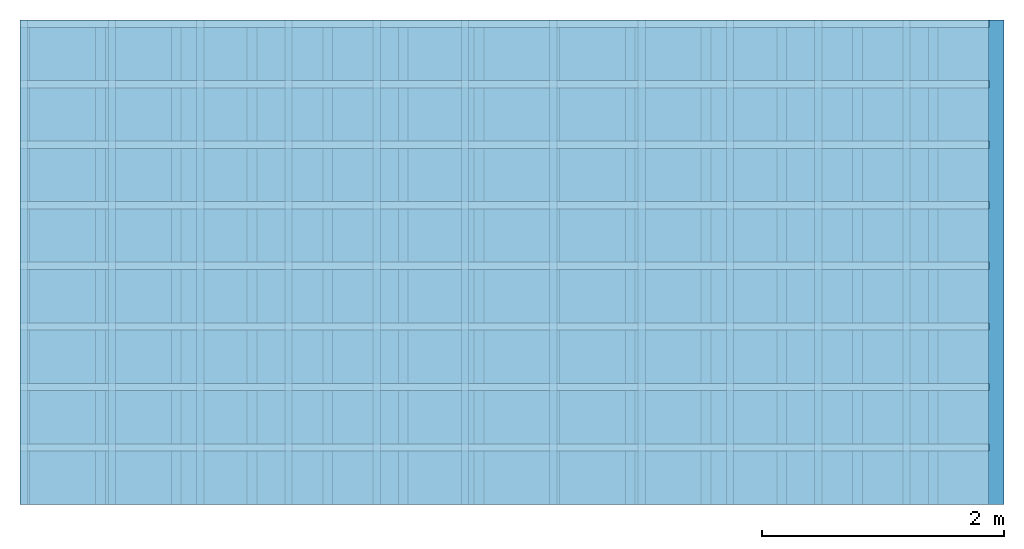
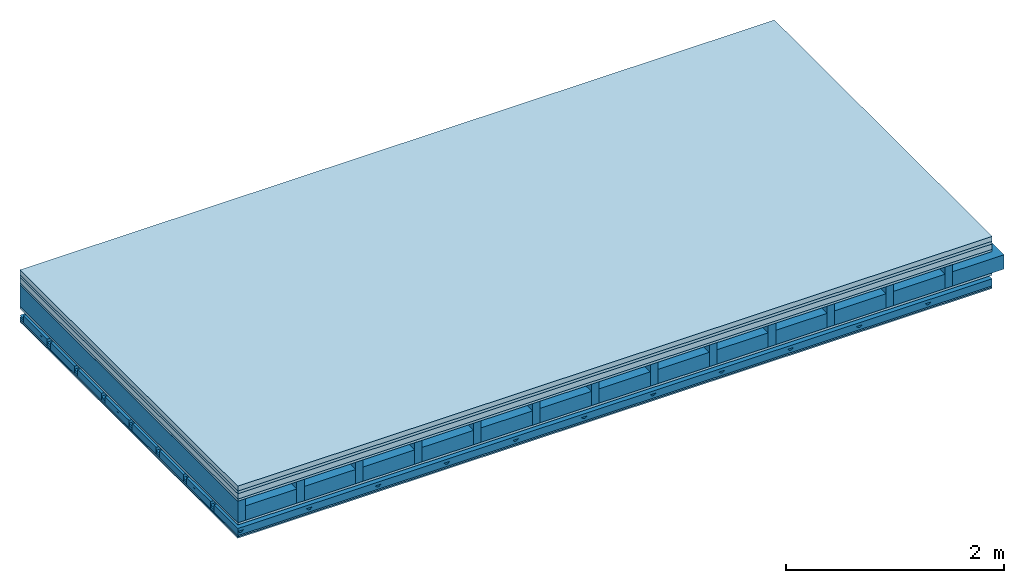
# One storey: 7 plates, 5 members, 1 element without a shape of its own.
"""IFC4 building model written with IfcOpenShell, lengths in metres."""

from ifc_helpers import new_model, si_unit, derived_unit, direction, frame, frame_2d, origin, origin_with_axes, place, context, project, spatial, polyline, rectangle, outline, extrude, material, layer, layer_set, type_object, element, aggregate, save


model = new_model("IFC4")

# Units and contexts
plan_context = context("Plan", 3, precision=1e-05, world=origin(), true_north=direction((0.0, 1.0)))
model_context = context("Model", 3, precision=1e-05, world=origin(), true_north=direction((0.0, 1.0)))
ifc_project = project(units=[si_unit("LENGTHUNIT", "METRE"), derived_unit("SOUNDPRESSUREUNIT", [(si_unit("PRESSUREUNIT", "PASCAL", prefix="MICRO"), 0)]), si_unit("ENERGYUNIT", "JOULE", prefix="MEGA"), si_unit("MASSUNIT", "GRAM", prefix="KILO"), derived_unit("THERMALTRANSMITTANCEUNIT", [(si_unit("POWERUNIT", "WATT"), 1), (si_unit("AREAUNIT", "SQUARE_METRE"), -1), (si_unit("THERMODYNAMICTEMPERATUREUNIT", "KELVIN"), -1)]), derived_unit("AREADENSITYUNIT", [(si_unit("MASSUNIT", "GRAM", prefix="KILO"), 1), (si_unit("AREAUNIT", "SQUARE_METRE"), -1)]), derived_unit("USERDEFINED", [(si_unit("ENERGYUNIT", "JOULE", prefix="MEGA"), 1), (si_unit("AREAUNIT", "SQUARE_METRE"), -1)])], contexts=[plan_context, model_context])

# Site, building, storey
site = spatial("IfcSite", under=ifc_project)
building_placement = place(None, origin())
building = spatial("IfcBuilding", under=site, at=building_placement)
storey_placement = place(building_placement, origin())
storey = spatial("IfcBuildingStorey", under=building, at=storey_placement)

# Slab, members, plates
ifc_material_1 = material(Category="04.005")
ifc_layer_1 = layer(ifc_material_1, 0.055, Name="On-material")
ifc_material_2 = material()
ifc_layer_2 = layer(ifc_material_2, 0.03, Name="Impact sound insulation")
ifc_material_3 = material(Name="Cement panels, glued on sub-floor", Category="02.007")
ifc_layer_3 = layer(ifc_material_3, 0.06, Name="on Supporting structure")
ifc_material_4 = material(Category="07.001")
ifc_layer_4 = layer(ifc_material_4, 0.025, Name="Sub-floor")
ifc_material_5 = material(Name="Rigid, of the art")
ifc_layer_5 = layer(ifc_material_5, 0.0, Name="Bond")
ifc_layer_6 = layer(None, 0.24, Name="Supporting structure")
ifc_layer_7 = layer(ifc_material_5, 0.0, Name="Bond")
ifc_layer_8 = layer(ifc_material_4, 0.025, Name="Lower layer 1")
ifc_layer_9 = layer(None, 0.093, Name="Coupling")
ifc_layer_10 = layer(None, 0.027, Name="Battens / profiles")
ifc_material_6 = material(Category="03.007")
ifc_layer_11 = layer(ifc_material_6, 0.015, Name="Ceiling covering 1st layer")
ifc_layer_12 = layer(ifc_material_6, 0.015, Name="Ceiling covering layer 2")
ifc_material_7 = material(Name="Glued joints")
ifc_layer_13 = layer(ifc_material_7, 0.0, Name="Surface / treatment")
ifc_layer_set = layer_set([ifc_layer_1, ifc_layer_2, ifc_layer_3, ifc_layer_4, ifc_layer_5, ifc_layer_6, ifc_layer_7, ifc_layer_8, ifc_layer_9, ifc_layer_10, ifc_layer_11, ifc_layer_12, ifc_layer_13])
slab_type = type_object("IfcSlabType", Name="A0520", PredefinedType="NOTDEFINED", material=ifc_layer_set)
slab_placement = place(None, frame((0.0, 0.0, 0.0), z_axis=(0.0, 0.0, -1.0), x_axis=(1.0, 0.0, 0.0)))
slab = element("IfcSlab", 1, at=slab_placement, inside=storey, type_object=slab_type, material=ifc_layer_set, Name="Slab #1")
ifc_material_8 = material()
member_1_placement = place(slab_placement, origin())
member_1 = element("IfcMember", 2, at=member_1_placement, material=ifc_material_8, Name="Supporting structure", context=plan_context, shape_type="SweptSolid", body=[
    extrude(rectangle(XDim=0.08, YDim=0.24, at=frame_2d((0.04, 0.12), x_axis=(1.0, 0.0))), frame((0.0, 4.0, 0.17), z_axis=(0.0, -1.0, 0.0), x_axis=(1.0, 0.0, 0.0)), (0.0, 0.0, 1.0), 4.0),
    extrude(rectangle(XDim=0.08, YDim=0.24, at=frame_2d((0.04, 0.12), x_axis=(1.0, 0.0))), frame((0.625, 4.0, 0.17), z_axis=(0.0, -1.0, 0.0), x_axis=(1.0, 0.0, 0.0)), (0.0, 0.0, 1.0), 4.0),
    extrude(rectangle(XDim=0.08, YDim=0.24, at=frame_2d((0.04, 0.12), x_axis=(1.0, 0.0))), frame((1.25, 4.0, 0.17), z_axis=(0.0, -1.0, 0.0), x_axis=(1.0, 0.0, 0.0)), (0.0, 0.0, 1.0), 4.0),
    extrude(rectangle(XDim=0.08, YDim=0.24, at=frame_2d((0.04, 0.12), x_axis=(1.0, 0.0))), frame((1.875, 4.0, 0.17), z_axis=(0.0, -1.0, 0.0), x_axis=(1.0, 0.0, 0.0)), (0.0, 0.0, 1.0), 4.0),
    extrude(rectangle(XDim=0.08, YDim=0.24, at=frame_2d((0.04, 0.12), x_axis=(1.0, 0.0))), frame((2.5, 4.0, 0.17), z_axis=(0.0, -1.0, 0.0), x_axis=(1.0, 0.0, 0.0)), (0.0, 0.0, 1.0), 4.0),
    extrude(rectangle(XDim=0.08, YDim=0.24, at=frame_2d((0.04, 0.12), x_axis=(1.0, 0.0))), frame((3.125, 4.0, 0.17), z_axis=(0.0, -1.0, 0.0), x_axis=(1.0, 0.0, 0.0)), (0.0, 0.0, 1.0), 4.0),
    extrude(rectangle(XDim=0.08, YDim=0.24, at=frame_2d((0.04, 0.12), x_axis=(1.0, 0.0))), frame((3.75, 4.0, 0.17), z_axis=(0.0, -1.0, 0.0), x_axis=(1.0, 0.0, 0.0)), (0.0, 0.0, 1.0), 4.0),
    extrude(rectangle(XDim=0.08, YDim=0.24, at=frame_2d((0.04, 0.12), x_axis=(1.0, 0.0))), frame((4.375, 4.0, 0.17), z_axis=(0.0, -1.0, 0.0), x_axis=(1.0, 0.0, 0.0)), (0.0, 0.0, 1.0), 4.0),
    extrude(rectangle(XDim=0.08, YDim=0.24, at=frame_2d((0.04, 0.12), x_axis=(1.0, 0.0))), frame((5.0, 4.0, 0.17), z_axis=(0.0, -1.0, 0.0), x_axis=(1.0, 0.0, 0.0)), (0.0, 0.0, 1.0), 4.0),
    extrude(rectangle(XDim=0.08, YDim=0.24, at=frame_2d((0.04, 0.12), x_axis=(1.0, 0.0))), frame((5.625, 4.0, 0.17), z_axis=(0.0, -1.0, 0.0), x_axis=(1.0, 0.0, 0.0)), (0.0, 0.0, 1.0), 4.0),
    extrude(rectangle(XDim=0.08, YDim=0.24, at=frame_2d((0.04, 0.12), x_axis=(1.0, 0.0))), frame((6.25, 4.0, 0.17), z_axis=(0.0, -1.0, 0.0), x_axis=(1.0, 0.0, 0.0)), (0.0, 0.0, 1.0), 4.0),
    extrude(rectangle(XDim=0.08, YDim=0.24, at=frame_2d((0.04, 0.12), x_axis=(1.0, 0.0))), frame((6.875, 4.0, 0.17), z_axis=(0.0, -1.0, 0.0), x_axis=(1.0, 0.0, 0.0)), (0.0, 0.0, 1.0), 4.0),
    extrude(rectangle(XDim=0.08, YDim=0.24, at=frame_2d((0.04, 0.12), x_axis=(1.0, 0.0))), frame((7.5, 4.0, 0.17), z_axis=(0.0, -1.0, 0.0), x_axis=(1.0, 0.0, 0.0)), (0.0, 0.0, 1.0), 4.0),
])
ifc_material_9 = material()
member_2_placement = place(slab_placement, origin())
member_2 = element("IfcMember", 3, at=member_2_placement, material=ifc_material_9, Name="Cavity", context=plan_context, shape_type="SweptSolid", body=[
    extrude(rectangle(XDim=0.545, YDim=0.16, at=frame_2d((0.2725, 0.08), x_axis=(1.0, 0.0))), frame((0.08, 4.0, 0.25), z_axis=(0.0, -1.0, 0.0), x_axis=(1.0, 0.0, 0.0)), (0.0, 0.0, 1.0), 4.0),
    extrude(rectangle(XDim=0.545, YDim=0.16, at=frame_2d((0.2725, 0.08), x_axis=(1.0, 0.0))), frame((0.705, 4.0, 0.25), z_axis=(0.0, -1.0, 0.0), x_axis=(1.0, 0.0, 0.0)), (0.0, 0.0, 1.0), 4.0),
    extrude(rectangle(XDim=0.545, YDim=0.16, at=frame_2d((0.2725, 0.08), x_axis=(1.0, 0.0))), frame((1.33, 4.0, 0.25), z_axis=(0.0, -1.0, 0.0), x_axis=(1.0, 0.0, 0.0)), (0.0, 0.0, 1.0), 4.0),
    extrude(rectangle(XDim=0.545, YDim=0.16, at=frame_2d((0.2725, 0.08), x_axis=(1.0, 0.0))), frame((1.955, 4.0, 0.25), z_axis=(0.0, -1.0, 0.0), x_axis=(1.0, 0.0, 0.0)), (0.0, 0.0, 1.0), 4.0),
    extrude(rectangle(XDim=0.545, YDim=0.16, at=frame_2d((0.2725, 0.08), x_axis=(1.0, 0.0))), frame((2.58, 4.0, 0.25), z_axis=(0.0, -1.0, 0.0), x_axis=(1.0, 0.0, 0.0)), (0.0, 0.0, 1.0), 4.0),
    extrude(rectangle(XDim=0.545, YDim=0.16, at=frame_2d((0.2725, 0.08), x_axis=(1.0, 0.0))), frame((3.205, 4.0, 0.25), z_axis=(0.0, -1.0, 0.0), x_axis=(1.0, 0.0, 0.0)), (0.0, 0.0, 1.0), 4.0),
    extrude(rectangle(XDim=0.545, YDim=0.16, at=frame_2d((0.2725, 0.08), x_axis=(1.0, 0.0))), frame((3.83, 4.0, 0.25), z_axis=(0.0, -1.0, 0.0), x_axis=(1.0, 0.0, 0.0)), (0.0, 0.0, 1.0), 4.0),
    extrude(rectangle(XDim=0.545, YDim=0.16, at=frame_2d((0.2725, 0.08), x_axis=(1.0, 0.0))), frame((4.455, 4.0, 0.25), z_axis=(0.0, -1.0, 0.0), x_axis=(1.0, 0.0, 0.0)), (0.0, 0.0, 1.0), 4.0),
    extrude(rectangle(XDim=0.545, YDim=0.16, at=frame_2d((0.2725, 0.08), x_axis=(1.0, 0.0))), frame((5.08, 4.0, 0.25), z_axis=(0.0, -1.0, 0.0), x_axis=(1.0, 0.0, 0.0)), (0.0, 0.0, 1.0), 4.0),
    extrude(rectangle(XDim=0.545, YDim=0.16, at=frame_2d((0.2725, 0.08), x_axis=(1.0, 0.0))), frame((5.705, 4.0, 0.25), z_axis=(0.0, -1.0, 0.0), x_axis=(1.0, 0.0, 0.0)), (0.0, 0.0, 1.0), 4.0),
    extrude(rectangle(XDim=0.545, YDim=0.16, at=frame_2d((0.2725, 0.08), x_axis=(1.0, 0.0))), frame((6.33, 4.0, 0.25), z_axis=(0.0, -1.0, 0.0), x_axis=(1.0, 0.0, 0.0)), (0.0, 0.0, 1.0), 4.0),
    extrude(rectangle(XDim=0.545, YDim=0.16, at=frame_2d((0.2725, 0.08), x_axis=(1.0, 0.0))), frame((6.955, 4.0, 0.25), z_axis=(0.0, -1.0, 0.0), x_axis=(1.0, 0.0, 0.0)), (0.0, 0.0, 1.0), 4.0),
    extrude(rectangle(XDim=0.545, YDim=0.16, at=frame_2d((0.2725, 0.08), x_axis=(1.0, 0.0))), frame((7.58, 4.0, 0.25), z_axis=(0.0, -1.0, 0.0), x_axis=(1.0, 0.0, 0.0)), (0.0, 0.0, 1.0), 4.0),
])
ifc_material_10 = material()
member_3_placement = place(slab_placement, origin())
member_3 = element("IfcMember", 4, at=member_3_placement, material=ifc_material_10, Name="Coupling", context=plan_context, shape_type="SweptSolid", body=[
    extrude(outline(polyline([(0.0, 0.0), (0.06, 0.0), (0.04, 0.02), (0.02, 0.02), (0.0, 0.0)])), frame((0.0, 4.0, 0.508), z_axis=(0.0, -1.0, 0.0), x_axis=(1.0, 0.0, 0.0)), (0.0, 0.0, 1.0), 4.0),
    extrude(outline(polyline([(0.0, 0.0), (0.06, 0.0), (0.04, 0.02), (0.02, 0.02), (0.0, 0.0)])), frame((0.729, 4.0, 0.508), z_axis=(0.0, -1.0, 0.0), x_axis=(1.0, 0.0, 0.0)), (0.0, 0.0, 1.0), 4.0),
    extrude(outline(polyline([(0.0, 0.0), (0.06, 0.0), (0.04, 0.02), (0.02, 0.02), (0.0, 0.0)])), frame((1.458, 4.0, 0.508), z_axis=(0.0, -1.0, 0.0), x_axis=(1.0, 0.0, 0.0)), (0.0, 0.0, 1.0), 4.0),
    extrude(outline(polyline([(0.0, 0.0), (0.06, 0.0), (0.04, 0.02), (0.02, 0.02), (0.0, 0.0)])), frame((2.187, 4.0, 0.508), z_axis=(0.0, -1.0, 0.0), x_axis=(1.0, 0.0, 0.0)), (0.0, 0.0, 1.0), 4.0),
    extrude(outline(polyline([(0.0, 0.0), (0.06, 0.0), (0.04, 0.02), (0.02, 0.02), (0.0, 0.0)])), frame((2.916, 4.0, 0.508), z_axis=(0.0, -1.0, 0.0), x_axis=(1.0, 0.0, 0.0)), (0.0, 0.0, 1.0), 4.0),
    extrude(outline(polyline([(0.0, 0.0), (0.06, 0.0), (0.04, 0.02), (0.02, 0.02), (0.0, 0.0)])), frame((3.645, 4.0, 0.508), z_axis=(0.0, -1.0, 0.0), x_axis=(1.0, 0.0, 0.0)), (0.0, 0.0, 1.0), 4.0),
    extrude(outline(polyline([(0.0, 0.0), (0.06, 0.0), (0.04, 0.02), (0.02, 0.02), (0.0, 0.0)])), frame((4.374, 4.0, 0.508), z_axis=(0.0, -1.0, 0.0), x_axis=(1.0, 0.0, 0.0)), (0.0, 0.0, 1.0), 4.0),
    extrude(outline(polyline([(0.0, 0.0), (0.06, 0.0), (0.04, 0.02), (0.02, 0.02), (0.0, 0.0)])), frame((5.103, 4.0, 0.508), z_axis=(0.0, -1.0, 0.0), x_axis=(1.0, 0.0, 0.0)), (0.0, 0.0, 1.0), 4.0),
    extrude(outline(polyline([(0.0, 0.0), (0.06, 0.0), (0.04, 0.02), (0.02, 0.02), (0.0, 0.0)])), frame((5.832, 4.0, 0.508), z_axis=(0.0, -1.0, 0.0), x_axis=(1.0, 0.0, 0.0)), (0.0, 0.0, 1.0), 4.0),
    extrude(outline(polyline([(0.0, 0.0), (0.06, 0.0), (0.04, 0.02), (0.02, 0.02), (0.0, 0.0)])), frame((6.561, 4.0, 0.508), z_axis=(0.0, -1.0, 0.0), x_axis=(1.0, 0.0, 0.0)), (0.0, 0.0, 1.0), 4.0),
    extrude(outline(polyline([(0.0, 0.0), (0.06, 0.0), (0.04, 0.02), (0.02, 0.02), (0.0, 0.0)])), frame((7.29, 4.0, 0.508), z_axis=(0.0, -1.0, 0.0), x_axis=(1.0, 0.0, 0.0)), (0.0, 0.0, 1.0), 4.0),
])
ifc_material_11 = material()
member_4_placement = place(slab_placement, origin())
member_4 = element("IfcMember", 5, at=member_4_placement, material=ifc_material_11, Name="Battens / profiles", context=plan_context, shape_type="SweptSolid", body=[
    extrude(rectangle(XDim=0.06, YDim=0.027, at=frame_2d((0.03, 0.0135), x_axis=(1.0, 0.0))), frame((0.0, 0.0, 0.528), z_axis=(1.0, 0.0, 0.0), x_axis=(0.0, 1.0, 0.0)), (0.0, 0.0, 1.0), 8.0),
    extrude(rectangle(XDim=0.06, YDim=0.027, at=frame_2d((0.03, 0.0135), x_axis=(1.0, 0.0))), frame((0.0, 0.5, 0.528), z_axis=(1.0, 0.0, 0.0), x_axis=(0.0, 1.0, 0.0)), (0.0, 0.0, 1.0), 8.0),
    extrude(rectangle(XDim=0.06, YDim=0.027, at=frame_2d((0.03, 0.0135), x_axis=(1.0, 0.0))), frame((0.0, 1.0, 0.528), z_axis=(1.0, 0.0, 0.0), x_axis=(0.0, 1.0, 0.0)), (0.0, 0.0, 1.0), 8.0),
    extrude(rectangle(XDim=0.06, YDim=0.027, at=frame_2d((0.03, 0.0135), x_axis=(1.0, 0.0))), frame((0.0, 1.5, 0.528), z_axis=(1.0, 0.0, 0.0), x_axis=(0.0, 1.0, 0.0)), (0.0, 0.0, 1.0), 8.0),
    extrude(rectangle(XDim=0.06, YDim=0.027, at=frame_2d((0.03, 0.0135), x_axis=(1.0, 0.0))), frame((0.0, 2.0, 0.528), z_axis=(1.0, 0.0, 0.0), x_axis=(0.0, 1.0, 0.0)), (0.0, 0.0, 1.0), 8.0),
    extrude(rectangle(XDim=0.06, YDim=0.027, at=frame_2d((0.03, 0.0135), x_axis=(1.0, 0.0))), frame((0.0, 2.5, 0.528), z_axis=(1.0, 0.0, 0.0), x_axis=(0.0, 1.0, 0.0)), (0.0, 0.0, 1.0), 8.0),
    extrude(rectangle(XDim=0.06, YDim=0.027, at=frame_2d((0.03, 0.0135), x_axis=(1.0, 0.0))), frame((0.0, 3.0, 0.528), z_axis=(1.0, 0.0, 0.0), x_axis=(0.0, 1.0, 0.0)), (0.0, 0.0, 1.0), 8.0),
    extrude(rectangle(XDim=0.06, YDim=0.027, at=frame_2d((0.03, 0.0135), x_axis=(1.0, 0.0))), frame((0.0, 3.5, 0.528), z_axis=(1.0, 0.0, 0.0), x_axis=(0.0, 1.0, 0.0)), (0.0, 0.0, 1.0), 8.0),
])
member_5_placement = place(slab_placement, origin())
member_5 = element("IfcMember", 6, at=member_5_placement, material=ifc_material_9, Name="Cavity", context=plan_context, shape_type="SweptSolid", body=[
    extrude(rectangle(XDim=0.44, YDim=0.08, at=frame_2d((0.22, 0.04), x_axis=(1.0, 0.0))), frame((0.0, 0.06, 0.475), z_axis=(1.0, 0.0, 0.0), x_axis=(0.0, 1.0, 0.0)), (0.0, 0.0, 1.0), 8.0),
    extrude(rectangle(XDim=0.44, YDim=0.08, at=frame_2d((0.22, 0.04), x_axis=(1.0, 0.0))), frame((0.0, 0.56, 0.475), z_axis=(1.0, 0.0, 0.0), x_axis=(0.0, 1.0, 0.0)), (0.0, 0.0, 1.0), 8.0),
    extrude(rectangle(XDim=0.44, YDim=0.08, at=frame_2d((0.22, 0.04), x_axis=(1.0, 0.0))), frame((0.0, 1.06, 0.475), z_axis=(1.0, 0.0, 0.0), x_axis=(0.0, 1.0, 0.0)), (0.0, 0.0, 1.0), 8.0),
    extrude(rectangle(XDim=0.44, YDim=0.08, at=frame_2d((0.22, 0.04), x_axis=(1.0, 0.0))), frame((0.0, 1.56, 0.475), z_axis=(1.0, 0.0, 0.0), x_axis=(0.0, 1.0, 0.0)), (0.0, 0.0, 1.0), 8.0),
    extrude(rectangle(XDim=0.44, YDim=0.08, at=frame_2d((0.22, 0.04), x_axis=(1.0, 0.0))), frame((0.0, 2.06, 0.475), z_axis=(1.0, 0.0, 0.0), x_axis=(0.0, 1.0, 0.0)), (0.0, 0.0, 1.0), 8.0),
    extrude(rectangle(XDim=0.44, YDim=0.08, at=frame_2d((0.22, 0.04), x_axis=(1.0, 0.0))), frame((0.0, 2.56, 0.475), z_axis=(1.0, 0.0, 0.0), x_axis=(0.0, 1.0, 0.0)), (0.0, 0.0, 1.0), 8.0),
    extrude(rectangle(XDim=0.44, YDim=0.08, at=frame_2d((0.22, 0.04), x_axis=(1.0, 0.0))), frame((0.0, 3.06, 0.475), z_axis=(1.0, 0.0, 0.0), x_axis=(0.0, 1.0, 0.0)), (0.0, 0.0, 1.0), 8.0),
    extrude(rectangle(XDim=0.44, YDim=0.08, at=frame_2d((0.22, 0.04), x_axis=(1.0, 0.0))), frame((0.0, 3.56, 0.475), z_axis=(1.0, 0.0, 0.0), x_axis=(0.0, 1.0, 0.0)), (0.0, 0.0, 1.0), 8.0),
])
plate_1_placement = place(slab_placement, origin())
plate_1 = element("IfcPlate", 7, at=plate_1_placement, material=ifc_material_1, Name="On-material", context=plan_context, shape_type="SweptSolid", body=[
    extrude(rectangle(XDim=8.0, YDim=4.0, at=frame_2d((4.0, 2.0), x_axis=(1.0, 0.0))), origin_with_axes(), (0.0, 0.0, 1.0), 0.055),
])
plate_2_placement = place(slab_placement, origin())
plate_2 = element("IfcPlate", 8, at=plate_2_placement, material=ifc_material_2, Name="Impact sound insulation", context=plan_context, shape_type="SweptSolid", body=[
    extrude(rectangle(XDim=8.0, YDim=4.0, at=frame_2d((4.0, 2.0), x_axis=(1.0, 0.0))), frame((0.0, 0.0, 0.055), z_axis=(0.0, 0.0, 1.0), x_axis=(1.0, 0.0, 0.0)), (0.0, 0.0, 1.0), 0.03),
])
plate_3_placement = place(slab_placement, origin())
plate_3 = element("IfcPlate", 9, at=plate_3_placement, material=ifc_material_3, Name="on Supporting structure", context=plan_context, shape_type="SweptSolid", body=[
    extrude(rectangle(XDim=8.0, YDim=4.0, at=frame_2d((4.0, 2.0), x_axis=(1.0, 0.0))), frame((0.0, 0.0, 0.085), z_axis=(0.0, 0.0, 1.0), x_axis=(1.0, 0.0, 0.0)), (0.0, 0.0, 1.0), 0.06),
])
plate_4_placement = place(slab_placement, origin())
plate_4 = element("IfcPlate", 10, at=plate_4_placement, material=ifc_material_4, Name="Sub-floor", context=plan_context, shape_type="SweptSolid", body=[
    extrude(rectangle(XDim=8.0, YDim=4.0, at=frame_2d((4.0, 2.0), x_axis=(1.0, 0.0))), frame((0.0, 0.0, 0.145), z_axis=(0.0, 0.0, 1.0), x_axis=(1.0, 0.0, 0.0)), (0.0, 0.0, 1.0), 0.025),
])
plate_5_placement = place(slab_placement, origin())
plate_5 = element("IfcPlate", 11, at=plate_5_placement, material=ifc_material_4, Name="Lower layer 1", context=plan_context, shape_type="SweptSolid", body=[
    extrude(rectangle(XDim=8.0, YDim=4.0, at=frame_2d((4.0, 2.0), x_axis=(1.0, 0.0))), frame((0.0, 0.0, 0.41), z_axis=(0.0, 0.0, 1.0), x_axis=(1.0, 0.0, 0.0)), (0.0, 0.0, 1.0), 0.025),
])
plate_6_placement = place(slab_placement, origin())
plate_6 = element("IfcPlate", 12, at=plate_6_placement, material=ifc_material_6, Name="Ceiling covering 1st layer", context=plan_context, shape_type="SweptSolid", body=[
    extrude(rectangle(XDim=8.0, YDim=4.0, at=frame_2d((4.0, 2.0), x_axis=(1.0, 0.0))), frame((0.0, 0.0, 0.555), z_axis=(0.0, 0.0, 1.0), x_axis=(1.0, 0.0, 0.0)), (0.0, 0.0, 1.0), 0.015),
])
plate_7_placement = place(slab_placement, origin())
plate_7 = element("IfcPlate", 13, at=plate_7_placement, material=ifc_material_6, Name="Ceiling covering layer 2", context=plan_context, shape_type="SweptSolid", body=[
    extrude(rectangle(XDim=8.0, YDim=4.0, at=frame_2d((4.0, 2.0), x_axis=(1.0, 0.0))), frame((0.0, 0.0, 0.57), z_axis=(0.0, 0.0, 1.0), x_axis=(1.0, 0.0, 0.0)), (0.0, 0.0, 1.0), 0.015),
])
aggregate(slab, [plate_1, plate_2, plate_3, plate_4, member_1, member_2, plate_5, member_3, member_4, member_5, plate_6, plate_7])

save(model, "model.ifc")
